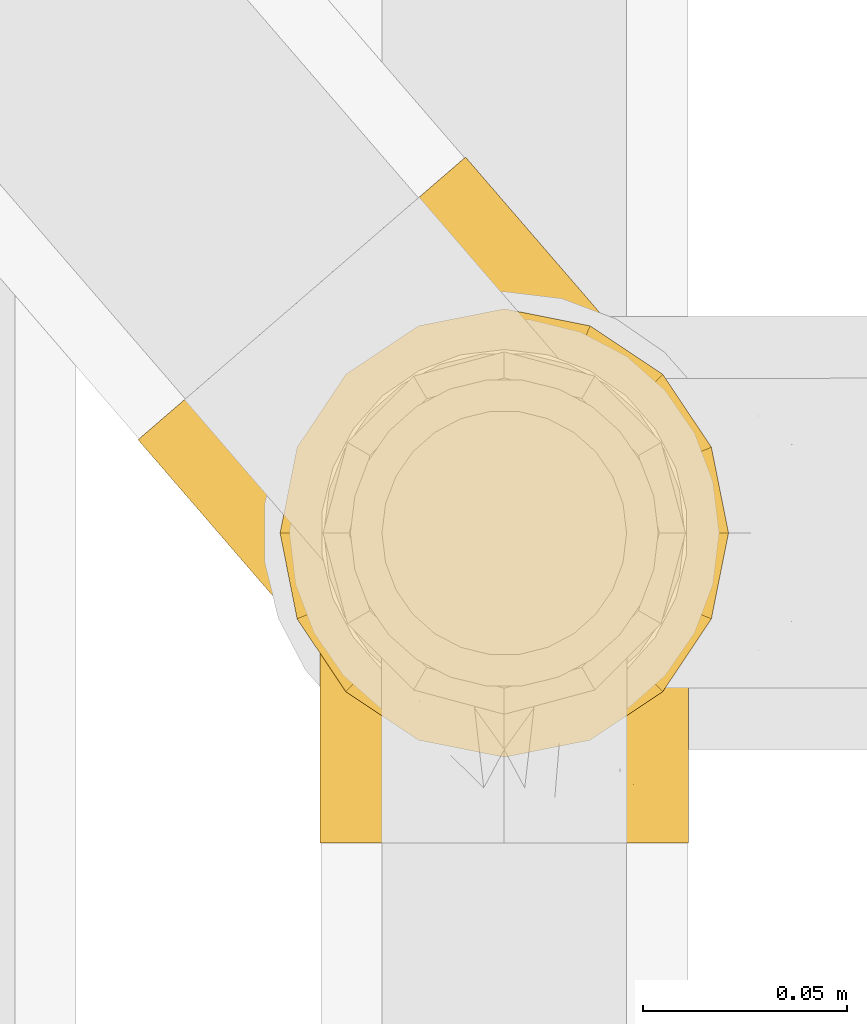
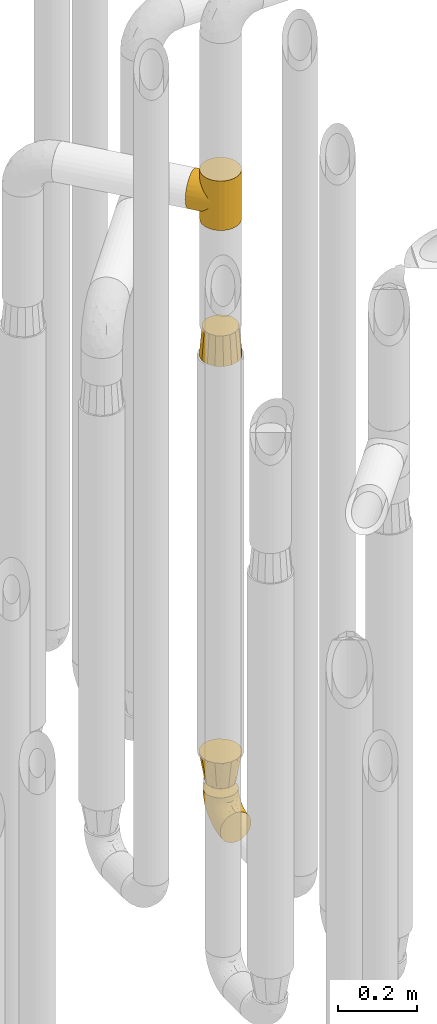
# One storey, part 217 of 827: 4 coverings.
"""IFC2X3 building model written with IfcOpenShell, lengths in millimetres."""

from ifc_helpers import new_model, entity, si_unit, converted_unit, derived_unit, direction, frame, origin, place, context, subcontext, project, spatial, faceted_brep, element, save


model = new_model("IFC2X3")

# Units and contexts
model_context = context("Model", 3, precision=0.01, world=origin(), true_north=direction((6.12303176911189e-17, 1.0)))
body_context = subcontext(model_context, "Body", "Model", "MODEL_VIEW")
ifc_project = project(units=[si_unit("LENGTHUNIT", "METRE", prefix="MILLI"), si_unit("AREAUNIT", "SQUARE_METRE"), si_unit("VOLUMEUNIT", "CUBIC_METRE"), converted_unit("PLANEANGLEUNIT", "DEGREE", entity("IfcRatioMeasure", 0.0174532925199433), si_unit("PLANEANGLEUNIT", "RADIAN"), dimensions=[0, 0, 0, 0, 0, 0, 0]), si_unit("MASSUNIT", "GRAM", prefix="KILO"), derived_unit("MASSDENSITYUNIT", [(si_unit("MASSUNIT", "GRAM", prefix="KILO"), 1), (si_unit("LENGTHUNIT", "METRE"), -3)]), derived_unit("MOMENTOFINERTIAUNIT", [(si_unit("LENGTHUNIT", "METRE"), 4)]), si_unit("TIMEUNIT", "SECOND"), si_unit("FREQUENCYUNIT", "HERTZ"), si_unit("THERMODYNAMICTEMPERATUREUNIT", "DEGREE_CELSIUS"), derived_unit("THERMALTRANSMITTANCEUNIT", [(si_unit("MASSUNIT", "GRAM", prefix="KILO"), 1), (si_unit("THERMODYNAMICTEMPERATUREUNIT", "KELVIN"), -1), (si_unit("TIMEUNIT", "SECOND"), -3)]), derived_unit("VOLUMETRICFLOWRATEUNIT", [(si_unit("LENGTHUNIT", "METRE"), 3), (si_unit("TIMEUNIT", "SECOND"), -1)]), derived_unit("MASSFLOWRATEUNIT", [(si_unit("MASSUNIT", "GRAM", prefix="KILO"), 1), (si_unit("TIMEUNIT", "SECOND"), -1)]), derived_unit("ROTATIONALFREQUENCYUNIT", [(si_unit("TIMEUNIT", "SECOND"), -1)]), si_unit("ELECTRICCURRENTUNIT", "AMPERE"), si_unit("ELECTRICVOLTAGEUNIT", "VOLT"), si_unit("POWERUNIT", "WATT"), si_unit("FORCEUNIT", "NEWTON", prefix="KILO"), si_unit("ILLUMINANCEUNIT", "LUX"), si_unit("LUMINOUSFLUXUNIT", "LUMEN"), si_unit("LUMINOUSINTENSITYUNIT", "CANDELA"), derived_unit("USERDEFINED", [(si_unit("MASSUNIT", "GRAM", prefix="KILO"), -1), (si_unit("LENGTHUNIT", "METRE"), -2), (si_unit("TIMEUNIT", "SECOND"), 3), (si_unit("LUMINOUSFLUXUNIT", "LUMEN"), 1)]), derived_unit("LINEARVELOCITYUNIT", [(si_unit("LENGTHUNIT", "METRE"), 1), (si_unit("TIMEUNIT", "SECOND"), -1)]), si_unit("PRESSUREUNIT", "PASCAL"), derived_unit("USERDEFINED", [(si_unit("LENGTHUNIT", "METRE"), -2), (si_unit("MASSUNIT", "GRAM", prefix="KILO"), 1), (si_unit("TIMEUNIT", "SECOND"), -2)]), derived_unit("LINEARFORCEUNIT", [(si_unit("MASSUNIT", "GRAM", prefix="KILO"), 1), (si_unit("LENGTHUNIT", "METRE"), 1), (si_unit("TIMEUNIT", "SECOND"), -2), (si_unit("LENGTHUNIT", "METRE"), -1)]), derived_unit("PLANARFORCEUNIT", [(si_unit("MASSUNIT", "GRAM", prefix="KILO"), 1), (si_unit("LENGTHUNIT", "METRE"), 1), (si_unit("TIMEUNIT", "SECOND"), -2), (si_unit("LENGTHUNIT", "METRE"), -2)])], contexts=[model_context])

# Site, building, storey
site_placement = place(None, origin())
site = spatial("IfcSite", under=ifc_project, at=site_placement, CompositionType="ELEMENT")
building_placement = place(site_placement, origin())
building = spatial("IfcBuilding", under=site, at=building_placement, CompositionType="ELEMENT")
storey_placement = place(building_placement, frame((0.0, 0.0, 28200.0)))
storey = spatial("IfcBuildingStorey", under=building, at=storey_placement, Name="08", CompositionType="ELEMENT", Elevation=28200.0)

# Coverings
covering_1_placement = place(storey_placement, frame((36928.29, 11252.61, 353.25)))
element("IfcCovering", 1, at=covering_1_placement, inside=storey, Name=":ADSK_", ObjectType=":ADSK_", PredefinedType="INSULATION", context=body_context, shape_type="Brep", body=[
    faceted_brep([(90.76, 87.65, 122.75), (87.42, 97.19, 122.75), (82.04, 105.75, 122.75), (74.89, 112.9, 122.75), (66.33, 118.28, 122.75), (56.79, 121.61, 122.75), (46.75, 122.75, 122.75), (36.69, 121.61, 122.75), (27.15, 118.27, 122.75), (18.59, 112.89, 122.75), (11.44, 105.74, 122.75), (6.06, 97.18, 122.75), (2.73, 87.64, 122.75), (1.6, 77.6, 122.75), (2.73, 67.54, 122.75), (6.07, 58.0, 122.75), (11.45, 49.44, 122.75), (18.6, 42.29, 122.75), (27.16, 36.91, 122.75), (36.7, 33.58, 122.75), (46.75, 32.45, 122.75), (56.8, 33.58, 122.75), (66.34, 36.92, 122.75), (74.9, 42.3, 122.75), (82.05, 49.45, 122.75), (87.43, 58.01, 122.75), (90.76, 67.55, 122.75), (91.9, 77.6, 122.75), (35.06, 1.6, 90.36), (24.17, 1.6, 85.85), (14.82, 1.6, 78.67), (7.64, 1.6, 69.32), (3.13, 1.6, 58.43), (1.6, 1.6, 46.75), (3.13, 1.6, 35.06), (7.64, 1.6, 24.17), (14.82, 1.6, 14.82), (24.17, 1.6, 7.64), (35.06, 1.6, 3.13), (46.75, 1.6, 1.6), (58.43, 1.6, 3.13), (69.32, 1.6, 7.64), (78.67, 1.6, 14.82), (85.85, 1.6, 24.17), (90.36, 1.6, 35.06), (91.9, 1.6, 46.75), (90.36, 1.6, 58.43), (85.85, 1.6, 69.32), (78.67, 1.6, 78.67), (69.32, 1.6, 85.85), (58.43, 1.6, 90.36), (46.75, 1.6, 91.9), (46.75, 99.61, 51.54), (55.2, 95.26, 47.17), (46.75, 86.21, 38.13), (46.75, 39.03, 7.52), (54.53, 30.75, 5.85), (46.75, 23.8, 5.11), (59.63, 60.8, 19.2), (62.07, 85.37, 38.98), (71.86, 73.64, 35.02), (62.65, 31.01, 8.21), (71.33, 49.14, 19.28), (72.93, 23.88, 12.19), (91.2, 82.74, 101.39), (86.31, 43.48, 34.43), (80.89, 29.47, 20.95), (79.49, 56.38, 30.74), (90.68, 72.18, 72.93), (86.84, 72.24, 56.64), (87.38, 87.6, 80.81), (76.87, 107.24, 93.43), (83.73, 101.1, 100.76), (81.03, 95.16, 74.27), (91.9, 71.81, 93.66), (91.9, 63.57, 81.33), (91.9, 55.34, 69.01), (91.03, 23.66, 40.87), (87.58, 20.55, 29.38), (56.52, 107.97, 67.05), (46.75, 116.82, 85.31), (60.4, 117.03, 93.68), (91.9, 30.68, 52.53), (91.9, 21.51, 50.71), (91.9, 12.33, 48.88), (67.87, 106.17, 72.77), (90.35, 52.37, 51.21), (69.57, 114.51, 101.18), (46.75, 119.23, 100.54), (79.91, 78.37, 48.74), (91.9, 75.46, 112.01), (91.9, 73.63, 102.83), (74.99, 101.51, 73.88), (46.75, 72.81, 24.73), (91.9, 43.01, 60.77), (88.53, 92.6, 103.08), (72.65, 91.86, 54.8), (46.75, 55.92, 16.13), (62.97, 99.01, 55.92), (46.75, 108.21, 68.42), (66.2, 32.05, 104.98), (56.6, 30.22, 108.58), (59.89, 23.37, 98.21), (90.95, 28.43, 61.56), (90.22, 16.44, 60.69), (76.64, 37.1, 100.0), (71.58, 28.88, 95.88), (79.99, 33.93, 90.81), (89.54, 50.17, 84.88), (89.97, 40.57, 73.29), (81.32, 47.62, 113.4), (74.56, 39.9, 109.8), (84.15, 47.92, 102.13), (90.37, 34.27, 67.29), (87.82, 24.65, 70.34), (90.98, 62.6, 95.15), (90.96, 66.18, 105.49), (85.14, 11.74, 71.5), (58.11, 13.89, 92.87), (46.75, 17.02, 96.03), (78.39, 15.86, 81.34), (88.22, 57.71, 107.44), (66.06, 9.11, 88.36), (68.6, 18.55, 90.43), (63.78, 34.74, 114.37), (88.42, 54.95, 98.41), (90.61, 57.35, 88.73), (83.8, 22.03, 76.89), (77.98, 24.8, 86.08), (91.22, 69.07, 112.64), (83.46, 42.31, 94.21), (46.75, 29.63, 112.22), (46.75, 28.31, 107.32), (84.66, 30.23, 79.95), (86.33, 40.13, 84.51), (46.75, 22.67, 101.67), (46.75, 12.12, 94.71), (15.1, 15.86, 81.34), (9.69, 22.03, 76.89), (15.52, 24.8, 86.08), (8.83, 30.23, 79.96), (35.39, 13.88, 92.87), (12.18, 47.61, 113.41), (1.6, 73.63, 102.83), (2.53, 66.17, 105.5), (2.27, 69.07, 112.64), (36.9, 30.22, 108.58), (27.31, 32.04, 104.98), (33.62, 23.36, 98.2), (5.07, 54.93, 98.4), (9.36, 47.91, 102.13), (5.27, 57.69, 107.44), (27.43, 9.1, 88.36), (1.6, 21.51, 50.71), (1.6, 12.33, 48.88), (10.05, 42.29, 94.22), (16.87, 37.09, 100.01), (8.35, 11.74, 71.5), (3.27, 16.44, 60.69), (1.6, 30.68, 52.53), (21.94, 28.86, 95.89), (29.72, 34.74, 114.37), (1.6, 63.57, 81.33), (1.6, 55.34, 69.01), (3.96, 50.17, 84.88), (1.6, 75.46, 112.01), (18.95, 39.89, 109.8), (2.54, 28.43, 61.56), (3.12, 34.27, 67.29), (1.6, 43.01, 60.77), (2.51, 62.59, 95.14), (3.52, 40.57, 73.29), (7.17, 40.13, 84.53), (1.6, 71.81, 93.66), (13.52, 33.92, 90.82), (2.88, 57.34, 88.73), (5.67, 24.65, 70.34), (24.89, 18.54, 90.43), (12.6, 29.47, 20.95), (7.18, 43.48, 34.43), (14.0, 56.4, 30.74), (22.16, 49.17, 19.29), (21.61, 73.69, 35.07), (3.14, 52.37, 51.21), (6.65, 72.26, 56.67), (20.82, 91.88, 54.85), (31.41, 85.36, 38.98), (5.91, 20.55, 29.38), (2.46, 23.66, 40.87), (33.87, 60.8, 19.2), (30.84, 31.02, 8.21), (38.96, 30.75, 5.85), (20.56, 23.9, 12.19), (2.81, 72.17, 72.93), (6.1, 87.59, 80.83), (2.29, 82.74, 101.39), (33.08, 117.03, 93.69), (16.61, 107.23, 93.43), (36.96, 107.97, 67.04), (9.75, 101.08, 100.76), (25.61, 106.17, 72.78), (30.5, 99.01, 55.93), (23.91, 114.5, 101.18), (12.45, 95.15, 74.27), (18.49, 101.5, 73.89), (4.96, 92.59, 103.09), (13.56, 78.38, 48.78), (38.28, 95.27, 47.19)], [[[0, 1, 2, 3, 4, 5, 6, 7, 8, 9, 10, 11, 12, 13, 14, 15, 16, 17, 18, 19, 20, 21, 22, 23, 24, 25, 26, 27]], [[28, 29, 30, 31, 32, 33, 34, 35, 36, 37, 38, 39, 40, 41, 42, 43, 44, 45, 46, 47, 48, 49, 50, 51]], [[52, 53, 54]], [[55, 56, 57]], [[58, 59, 60]], [[61, 62, 63]], [[27, 64, 0]], [[65, 66, 67]], [[41, 40, 61]], [[68, 69, 70]], [[66, 43, 42]], [[63, 42, 41]], [[71, 72, 73]], [[72, 2, 1]], [[68, 74, 75, 76]], [[45, 44, 77]], [[43, 78, 44]], [[79, 80, 81]], [[77, 82, 83, 84, 45]], [[79, 81, 85]], [[71, 2, 72]], [[65, 86, 77]], [[4, 81, 5]], [[66, 65, 78]], [[4, 3, 87]], [[81, 88, 5]], [[63, 66, 42]], [[68, 70, 64]], [[67, 60, 89]], [[71, 3, 2]], [[64, 27, 90, 91, 74]], [[92, 71, 73]], [[40, 57, 56]], [[59, 93, 54]], [[86, 76, 94, 82]], [[1, 0, 95]], [[58, 62, 61]], [[60, 96, 89]], [[85, 81, 87]], [[56, 97, 58]], [[65, 67, 69]], [[87, 81, 4]], [[67, 89, 69]], [[61, 63, 41]], [[95, 72, 1]], [[73, 72, 70]], [[69, 73, 70]], [[73, 89, 96]], [[3, 71, 87]], [[85, 87, 71]], [[58, 61, 56]], [[59, 58, 93]], [[76, 86, 68]], [[69, 89, 73]], [[68, 86, 69]], [[65, 69, 86]], [[68, 64, 74]], [[95, 64, 70]], [[98, 79, 85]], [[79, 52, 99, 80]], [[66, 62, 67]], [[62, 58, 60]], [[62, 60, 67]], [[59, 98, 96]], [[59, 96, 60]], [[96, 85, 92]], [[88, 81, 80]], [[88, 6, 5]], [[66, 63, 62]], [[64, 95, 0]], [[72, 95, 70]], [[77, 44, 78]], [[86, 82, 77]], [[40, 39, 57]], [[96, 98, 85]], [[40, 56, 61]], [[66, 78, 43]], [[77, 78, 65]], [[79, 98, 53]], [[96, 92, 73]], [[85, 71, 92]], [[97, 56, 55]], [[97, 93, 58]], [[53, 98, 59]], [[54, 53, 59]], [[79, 53, 52]], [[100, 101, 102]], [[46, 45, 84, 83]], [[103, 104, 82]], [[82, 104, 83]], [[105, 106, 107]], [[108, 109, 76]], [[110, 111, 112]], [[103, 113, 114]], [[115, 74, 116]], [[48, 47, 117]], [[118, 102, 119]], [[49, 48, 120]], [[74, 91, 116]], [[116, 121, 115]], [[49, 122, 50]], [[123, 106, 102]], [[124, 111, 22]], [[125, 126, 115]], [[23, 22, 111]], [[24, 110, 121]], [[120, 127, 128]], [[90, 26, 129]], [[27, 26, 90]], [[121, 125, 115]], [[24, 121, 25]], [[130, 105, 107]], [[129, 25, 116]], [[21, 20, 131]], [[120, 123, 122]], [[112, 105, 130]], [[50, 118, 51]], [[21, 124, 22]], [[101, 131, 132]], [[117, 120, 48]], [[24, 23, 110]], [[127, 114, 133]], [[75, 108, 76]], [[107, 134, 130]], [[133, 114, 113]], [[129, 116, 91]], [[25, 121, 116]], [[121, 112, 125]], [[75, 74, 115]], [[101, 135, 102]], [[131, 101, 21]], [[101, 100, 124]], [[128, 127, 133]], [[119, 136, 51, 118]], [[104, 47, 46]], [[83, 104, 46]], [[117, 104, 114]], [[101, 124, 21]], [[111, 124, 100]], [[102, 118, 123]], [[133, 134, 107]], [[111, 110, 23]], [[114, 104, 103]], [[94, 76, 109]], [[121, 110, 112]], [[122, 118, 50]], [[134, 109, 108]], [[133, 107, 128]], [[112, 108, 125]], [[126, 125, 108]], [[108, 75, 126]], [[75, 115, 126]], [[109, 134, 133]], [[130, 108, 112]], [[108, 130, 134]], [[105, 112, 111]], [[111, 100, 105]], [[106, 105, 100]], [[102, 106, 100]], [[128, 106, 123]], [[90, 129, 91]], [[25, 129, 26]], [[104, 117, 47]], [[117, 114, 127]], [[82, 94, 103]], [[113, 94, 109]], [[94, 113, 103]], [[133, 113, 109]], [[106, 128, 107]], [[123, 120, 128]], [[120, 122, 49]], [[118, 122, 123]], [[135, 101, 132]], [[135, 119, 102]], [[117, 127, 120]], [[30, 29, 137]], [[138, 139, 140]], [[51, 136, 119, 141]], [[142, 17, 16]], [[143, 144, 145]], [[146, 147, 148]], [[149, 150, 151]], [[152, 29, 28]], [[33, 32, 153, 154]], [[150, 155, 156]], [[157, 31, 30]], [[153, 158, 159]], [[29, 152, 137]], [[148, 141, 119]], [[156, 160, 147]], [[148, 135, 146]], [[137, 138, 157]], [[19, 161, 146]], [[162, 163, 164]], [[14, 13, 165]], [[153, 32, 158]], [[147, 161, 166]], [[18, 17, 166]], [[167, 168, 169]], [[166, 150, 156]], [[151, 150, 142]], [[151, 170, 149]], [[151, 16, 15]], [[171, 140, 172]], [[165, 143, 145]], [[173, 170, 144]], [[142, 166, 17]], [[19, 131, 20]], [[144, 170, 151]], [[18, 161, 19]], [[173, 144, 143]], [[140, 139, 174]], [[171, 164, 163]], [[164, 172, 155]], [[151, 15, 144]], [[145, 15, 14]], [[173, 162, 170]], [[149, 175, 164]], [[19, 146, 131]], [[132, 131, 146]], [[160, 148, 147]], [[159, 158, 167]], [[135, 132, 146]], [[158, 32, 31]], [[157, 158, 31]], [[167, 158, 176]], [[166, 161, 18]], [[146, 161, 147]], [[148, 177, 141]], [[171, 168, 140]], [[171, 163, 169]], [[151, 142, 16]], [[166, 142, 150]], [[152, 141, 177]], [[51, 141, 28]], [[138, 140, 176]], [[172, 140, 174]], [[175, 149, 170]], [[164, 150, 149]], [[170, 162, 175]], [[162, 164, 175]], [[155, 172, 174]], [[171, 172, 164]], [[155, 174, 156]], [[164, 155, 150]], [[160, 156, 174]], [[147, 166, 156]], [[139, 160, 174]], [[148, 160, 177]], [[15, 145, 144]], [[165, 145, 14]], [[137, 157, 30]], [[158, 157, 176]], [[168, 167, 176]], [[169, 159, 167]], [[140, 168, 176]], [[169, 168, 171]], [[137, 177, 139]], [[160, 139, 177]], [[141, 152, 28]], [[137, 152, 177]], [[148, 119, 135]], [[157, 138, 176]], [[139, 138, 137]], [[178, 179, 180]], [[181, 180, 182]], [[179, 183, 184]], [[185, 186, 182]], [[187, 188, 179]], [[188, 33, 154, 153, 159]], [[181, 189, 190]], [[35, 34, 187]], [[191, 38, 190]], [[192, 178, 181]], [[179, 184, 180]], [[192, 190, 37]], [[37, 190, 38]], [[36, 35, 178]], [[54, 93, 186]], [[35, 187, 178]], [[193, 194, 184]], [[195, 173, 143, 165, 13]], [[195, 193, 173]], [[193, 163, 162, 173]], [[13, 12, 195]], [[8, 7, 196]], [[9, 197, 10]], [[198, 80, 99, 52]], [[196, 7, 88]], [[197, 199, 10]], [[182, 189, 181]], [[200, 198, 201]], [[200, 196, 198]], [[9, 8, 202]], [[194, 199, 203]], [[192, 37, 36]], [[80, 196, 88]], [[183, 159, 169, 163]], [[188, 34, 33]], [[202, 200, 197]], [[185, 203, 204]], [[202, 8, 196]], [[10, 199, 11]], [[12, 11, 205]], [[38, 191, 57]], [[189, 97, 191]], [[203, 199, 197]], [[205, 199, 194]], [[204, 203, 197]], [[184, 203, 206]], [[200, 202, 196]], [[197, 9, 202]], [[207, 54, 186]], [[97, 55, 191]], [[194, 203, 184]], [[183, 163, 193]], [[184, 206, 180]], [[183, 193, 184]], [[205, 195, 12]], [[193, 195, 194]], [[80, 198, 196]], [[207, 186, 201]], [[182, 180, 206]], [[181, 178, 180]], [[185, 182, 206]], [[182, 186, 189]], [[203, 185, 206]], [[185, 200, 201]], [[7, 6, 88]], [[178, 192, 36]], [[190, 192, 181]], [[199, 205, 11]], [[195, 205, 194]], [[159, 183, 188]], [[179, 188, 183]], [[57, 191, 55]], [[57, 39, 38]], [[189, 191, 190]], [[188, 187, 34]], [[178, 187, 179]], [[186, 93, 189]], [[197, 200, 204]], [[185, 204, 200]], [[189, 93, 97]], [[207, 198, 52]], [[185, 201, 186]], [[198, 207, 201]], [[54, 207, 52]]]),
])
covering_2_placement = place(storey_placement, frame((36883.62, 11275.7, 2229.0)))
element("IfcCovering", 2, at=covering_2_placement, inside=storey, Name=":ADSK_", ObjectType=":ADSK_", PredefinedType="INSULATION", context=body_context, shape_type="Brep", body=[
    faceted_brep([(49.11, 86.52, 24.13), (56.75, 94.67, 22.95), (56.75, 94.67, 0.0), (56.75, 94.67, 129.05), (49.11, 86.52, 127.87), (56.75, 94.67, 152.0), (47.54, 84.33, 0.0), (43.53, 77.34, 27.43), (44.43, 78.14, 0.0), (41.31, 71.96, 0.0), (38.5, 58.4, 0.0), (38.51, 58.49, 38.42), (40.06, 67.84, 32.36), (38.59, 49.55, 45.24), (39.3, 44.57, 0.0), (40.07, 41.15, 52.57), (43.64, 31.42, 0.0), (46.51, 26.24, 68.06), (51.25, 19.84, 0.0), (42.75, 33.36, 60.22), (51.25, 19.84, 76.0), (46.51, 26.24, 83.94), (51.25, 19.84, 152.0), (126.54, 94.25, 68.86), (131.57, 89.16, 0.0), (121.24, 98.37, 0.0), (108.86, 104.6, 0.0), (114.42, 102.3, 54.84), (99.72, 106.9, 41.76), (95.3, 107.41, 0.0), (107.37, 105.09, 48.13), (131.57, 89.16, 76.0), (126.54, 94.25, 83.14), (131.57, 89.16, 152.0), (120.81, 98.66, 61.78), (91.49, 107.55, 35.89), (81.48, 106.61, 0.0), (73.82, 104.55, 26.62), (74.9, 104.44, 0.0), (68.33, 102.27, 0.0), (62.54, 98.47, 0.0), (62.54, 98.47, 152.0), (82.79, 106.85, 30.74), (64.96, 100.49, 23.9), (114.49, 6.74, 152.0), (126.07, 14.34, 152.0), (135.28, 24.68, 152.0), (141.51, 37.05, 152.0), (144.32, 50.61, 152.0), (143.52, 64.43, 152.0), (139.18, 77.58, 152.0), (121.24, 98.37, 152.0), (108.86, 104.6, 152.0), (95.3, 107.41, 152.0), (81.48, 106.61, 152.0), (74.9, 104.44, 152.0), (68.33, 102.27, 152.0), (47.54, 84.33, 152.0), (44.43, 78.14, 152.0), (41.31, 71.96, 152.0), (38.5, 58.4, 152.0), (39.3, 44.57, 152.0), (43.64, 31.42, 152.0), (61.58, 10.63, 152.0), (73.96, 4.41, 152.0), (87.52, 1.6, 152.0), (101.34, 2.39, 152.0), (139.18, 77.58, 0.0), (143.52, 64.43, 0.0), (144.32, 50.61, 0.0), (141.51, 37.05, 0.0), (135.28, 24.68, 0.0), (126.07, 14.34, 0.0), (114.49, 6.74, 0.0), (101.34, 2.39, 0.0), (87.52, 1.6, 0.0), (73.96, 4.41, 0.0), (61.58, 10.63, 0.0), (120.81, 98.66, 90.22), (114.42, 102.3, 97.16), (107.37, 105.09, 103.87), (99.72, 106.9, 110.24), (91.49, 107.55, 116.11), (82.79, 106.85, 121.26), (73.82, 104.55, 125.38), (64.96, 100.49, 128.1), (43.53, 77.34, 124.57), (40.06, 67.84, 119.64), (38.51, 58.49, 113.58), (40.07, 41.15, 99.43), (42.75, 33.36, 91.78), (38.59, 49.55, 106.76), (81.92, 146.7, 76.0), (80.55, 145.52, 62.27), (76.54, 142.06, 49.47), (70.16, 136.55, 38.49), (61.84, 129.37, 30.06), (57.0, 125.19, 27.41), (52.15, 121.01, 24.76), (46.96, 116.53, 23.85), (41.76, 112.04, 22.95), (31.36, 103.07, 24.76), (26.52, 98.89, 27.41), (21.68, 94.71, 30.06), (13.36, 87.54, 38.49), (6.98, 82.03, 49.47), (2.96, 78.56, 62.27), (1.6, 77.38, 76.0), (2.96, 78.56, 89.73), (6.98, 82.03, 102.53), (13.36, 87.54, 113.51), (21.68, 94.71, 121.94), (26.52, 98.89, 124.59), (31.36, 103.07, 127.24), (41.76, 112.04, 129.05), (46.96, 116.53, 128.15), (52.15, 121.01, 127.24), (57.0, 125.19, 124.59), (61.84, 129.37, 121.94), (70.16, 136.55, 113.51), (76.54, 142.06, 102.53), (80.55, 145.52, 89.73)], [[[0, 1, 2]], [[3, 4, 5]], [[0, 2, 6]], [[7, 6, 8, 9]], [[7, 0, 6]], [[10, 11, 12]], [[7, 9, 12]], [[12, 9, 10]], [[13, 10, 14]], [[15, 14, 16]], [[17, 16, 18]], [[15, 13, 14]], [[17, 19, 16]], [[20, 17, 18]], [[21, 20, 22]], [[15, 16, 19]], [[10, 13, 11]], [[23, 24, 25]], [[25, 26, 27]], [[28, 26, 29]], [[28, 30, 26]], [[23, 31, 24]], [[31, 32, 33]], [[27, 34, 25]], [[30, 27, 26]], [[23, 25, 34]], [[35, 29, 36]], [[37, 36, 38, 39]], [[40, 2, 1]], [[41, 3, 5]], [[42, 35, 36]], [[43, 37, 39]], [[43, 40, 1]], [[43, 39, 40]], [[42, 36, 37]], [[29, 35, 28]], [[44, 45, 46, 47, 48, 49, 50, 33, 51, 52, 53, 54, 55, 56, 41, 5, 57, 58, 59, 60, 61, 62, 22, 63, 64, 65, 66]], [[24, 67, 68, 69, 70, 71, 72, 73, 74, 75, 76, 77, 18, 16, 14, 10, 9, 8, 6, 2, 40, 39, 38, 36, 29, 26, 25]], [[70, 69, 48, 47]], [[45, 72, 71, 46]], [[46, 71, 70, 47]], [[49, 68, 67, 50]], [[24, 31, 33, 50, 67]], [[48, 69, 68, 49]], [[78, 79, 51]], [[32, 78, 51]], [[33, 32, 51]], [[52, 80, 81]], [[52, 51, 79]], [[52, 81, 53]], [[80, 52, 79]], [[82, 83, 54]], [[84, 56, 55, 54]], [[84, 85, 56]], [[3, 41, 85]], [[83, 84, 54]], [[53, 82, 54]], [[85, 41, 56]], [[82, 53, 81]], [[4, 86, 57]], [[59, 87, 60]], [[86, 59, 58, 57]], [[86, 87, 59]], [[5, 4, 57]], [[87, 88, 60]], [[89, 90, 62]], [[90, 21, 62]], [[60, 91, 61]], [[91, 60, 88]], [[89, 61, 91]], [[89, 62, 61]], [[21, 22, 62]], [[20, 18, 77, 63, 22]], [[63, 77, 76, 64]], [[76, 75, 65, 64]], [[65, 75, 74, 66]], [[66, 74, 73, 44]], [[44, 73, 72, 45]], [[92, 93, 94, 95, 96, 97, 98, 99, 100, 101, 102, 103, 104, 105, 106, 107, 108, 109, 110, 111, 112, 113, 114, 115, 116, 117, 118, 119, 120, 121]], [[43, 99, 98]], [[96, 95, 35]], [[37, 98, 97, 96]], [[1, 99, 43]], [[1, 100, 99]], [[42, 37, 96]], [[35, 42, 96]], [[43, 98, 37]], [[95, 28, 35]], [[30, 28, 94]], [[94, 28, 95]], [[27, 94, 93]], [[23, 93, 92]], [[27, 30, 94]], [[23, 34, 93]], [[31, 23, 92]], [[27, 93, 34]], [[32, 92, 121]], [[121, 120, 79]], [[81, 120, 119]], [[81, 80, 120]], [[32, 31, 92]], [[79, 78, 121]], [[80, 79, 120]], [[32, 121, 78]], [[82, 119, 118]], [[84, 118, 117, 116]], [[115, 114, 3]], [[83, 82, 118]], [[85, 84, 116]], [[85, 115, 3]], [[85, 116, 115]], [[83, 118, 84]], [[119, 82, 81]], [[4, 3, 114]], [[4, 114, 113]], [[86, 113, 112, 111]], [[86, 4, 113]], [[110, 88, 87]], [[86, 111, 87]], [[87, 111, 110]], [[91, 110, 109]], [[89, 109, 108]], [[21, 108, 107]], [[89, 91, 109]], [[21, 90, 108]], [[20, 21, 107]], [[89, 108, 90]], [[110, 91, 88]], [[17, 107, 106]], [[106, 105, 15]], [[13, 105, 104]], [[13, 15, 105]], [[17, 20, 107]], [[15, 19, 106]], [[17, 106, 19]], [[12, 104, 103]], [[7, 103, 102, 101]], [[0, 101, 100]], [[12, 11, 104]], [[0, 7, 101]], [[1, 0, 100]], [[12, 103, 7]], [[104, 11, 13]]]),
])
covering_3_placement = place(storey_placement, frame((36918.44, 11273.61, 500.0)))
element("IfcCovering", 3, at=covering_3_placement, inside=storey, Name=":ADSK_", ObjectType=":ADSK_", PredefinedType="INSULATION", context=body_context, shape_type="Brep", body=[
    faceted_brep([(5.78, 77.64, 89.0), (3.69, 67.12, 89.0), (1.6, 56.6, 89.0), (3.69, 46.07, 89.0), (5.78, 35.55, 89.0), (11.74, 26.63, 89.0), (17.7, 17.7, 89.0), (26.63, 11.74, 89.0), (35.55, 5.78, 89.0), (46.07, 3.69, 89.0), (56.6, 1.6, 89.0), (67.12, 3.69, 89.0), (77.64, 5.78, 89.0), (86.56, 11.74, 89.0), (95.49, 17.7, 89.0), (101.45, 26.63, 89.0), (107.41, 35.55, 89.0), (109.5, 46.07, 89.0), (111.6, 56.6, 89.0), (109.5, 67.12, 89.0), (107.41, 77.64, 89.0), (101.45, 86.56, 89.0), (95.49, 95.49, 89.0), (86.56, 101.45, 89.0), (77.64, 107.41, 89.0), (67.12, 109.5, 89.0), (56.6, 111.6, 89.0), (46.07, 109.5, 89.0), (35.55, 107.41, 89.0), (26.63, 101.45, 89.0), (17.7, 95.49, 89.0), (11.74, 86.56, 89.0), (91.24, 36.6, 0.0), (83.92, 29.27, 0.0), (76.6, 21.95, 0.0), (66.6, 19.27, 0.0), (56.6, 16.6, 0.0), (46.6, 19.27, 0.0), (36.6, 21.95, 0.0), (29.27, 29.27, 0.0), (21.95, 36.6, 0.0), (19.27, 46.6, 0.0), (16.6, 56.6, 0.0), (19.27, 66.6, 0.0), (21.95, 76.6, 0.0), (29.27, 83.92, 0.0), (36.6, 91.24, 0.0), (46.6, 93.92, 0.0), (56.6, 96.6, 0.0), (66.6, 93.92, 0.0), (76.6, 91.24, 0.0), (83.92, 83.92, 0.0), (91.24, 76.6, 0.0), (93.92, 66.6, 0.0), (96.6, 56.6, 0.0), (93.92, 46.6, 0.0)], [[[0, 1, 2, 3, 4, 5, 6, 7, 8, 9, 10, 11, 12, 13, 14, 15, 16, 17, 18, 19, 20, 21, 22, 23, 24, 25, 26, 27, 28, 29, 30, 31]], [[32, 33, 34, 35, 36, 37, 38, 39, 40, 41, 42, 43, 44, 45, 46, 47, 48, 49, 50, 51, 52, 53, 54, 55]], [[27, 26, 48]], [[44, 31, 45]], [[45, 29, 46]], [[48, 47, 27]], [[30, 45, 31]], [[44, 0, 31]], [[29, 45, 30]], [[42, 1, 43]], [[29, 28, 46]], [[47, 46, 28]], [[1, 42, 2]], [[0, 44, 43]], [[1, 0, 43]], [[47, 28, 27]], [[3, 2, 42]], [[38, 7, 39]], [[39, 5, 40]], [[42, 41, 3]], [[6, 39, 7]], [[38, 8, 7]], [[5, 39, 6]], [[36, 9, 37]], [[5, 4, 40]], [[41, 40, 4]], [[9, 36, 10]], [[8, 38, 37]], [[9, 8, 37]], [[41, 4, 3]], [[11, 10, 36]], [[32, 15, 33]], [[33, 13, 34]], [[36, 35, 11]], [[14, 33, 15]], [[32, 16, 15]], [[13, 33, 14]], [[54, 17, 55]], [[13, 12, 34]], [[35, 34, 12]], [[17, 54, 18]], [[16, 32, 55]], [[17, 16, 55]], [[35, 12, 11]], [[19, 18, 54]], [[50, 23, 51]], [[51, 21, 52]], [[54, 53, 19]], [[22, 51, 23]], [[50, 24, 23]], [[21, 51, 22]], [[48, 25, 49]], [[21, 20, 52]], [[53, 52, 20]], [[25, 48, 26]], [[24, 50, 49]], [[25, 24, 49]], [[53, 20, 19]]]),
])
covering_4_placement = place(storey_placement, frame((36918.44, 11273.61, 1811.0)))
element("IfcCovering", 4, at=covering_4_placement, inside=storey, Name=":ADSK_", ObjectType=":ADSK_", PredefinedType="INSULATION", context=body_context, shape_type="Brep", body=[
    faceted_brep([(56.6, 104.1, 89.0), (47.51, 102.29, 89.0), (38.42, 100.48, 89.0), (30.71, 95.33, 89.0), (23.01, 90.18, 89.0), (17.86, 82.48, 89.0), (12.71, 74.77, 89.0), (10.9, 65.68, 89.0), (9.1, 56.6, 89.0), (10.9, 47.51, 89.0), (12.71, 38.42, 89.0), (17.86, 30.71, 89.0), (23.01, 23.01, 89.0), (30.71, 17.86, 89.0), (38.42, 12.71, 89.0), (47.51, 10.9, 89.0), (56.6, 9.1, 89.0), (65.68, 10.9, 89.0), (74.77, 12.71, 89.0), (82.48, 17.86, 89.0), (90.18, 23.01, 89.0), (95.33, 30.71, 89.0), (100.48, 38.42, 89.0), (102.29, 47.51, 89.0), (104.1, 56.6, 89.0), (102.29, 65.68, 89.0), (100.48, 74.77, 89.0), (95.33, 82.48, 89.0), (90.18, 90.18, 89.0), (82.48, 95.33, 89.0), (74.77, 100.48, 89.0), (65.68, 102.29, 89.0), (77.64, 5.78, 0.0), (69.69, 4.2, 0.0), (56.6, 1.6, 0.0), (43.51, 4.2, 0.0), (35.55, 5.78, 0.0), (26.63, 11.74, 0.0), (17.7, 17.7, 0.0), (11.74, 26.63, 0.0), (5.78, 35.55, 0.0), (4.2, 43.51, 0.0), (1.6, 56.6, 0.0), (4.2, 69.69, 0.0), (5.78, 77.64, 0.0), (11.74, 86.56, 0.0), (17.7, 95.49, 0.0), (26.63, 101.45, 0.0), (35.55, 107.41, 0.0), (43.51, 108.99, 0.0), (56.6, 111.6, 0.0), (69.69, 108.99, 0.0), (77.64, 107.41, 0.0), (86.56, 101.45, 0.0), (95.49, 95.49, 0.0), (101.45, 86.56, 0.0), (107.41, 77.64, 0.0), (108.99, 69.69, 0.0), (111.6, 56.6, 0.0), (108.99, 43.51, 0.0), (107.41, 35.55, 0.0), (101.45, 26.63, 0.0), (95.49, 17.7, 0.0), (86.56, 11.74, 0.0)], [[[0, 1, 2, 3, 4, 5, 6, 7, 8, 9, 10, 11, 12, 13, 14, 15, 16, 17, 18, 19, 20, 21, 22, 23, 24, 25, 26, 27, 28, 29, 30, 31]], [[32, 33, 34, 35, 36, 37, 38, 39, 40, 41, 42, 43, 44, 45, 46, 47, 48, 49, 50, 51, 52, 53, 54, 55, 56, 57, 58, 59, 60, 61, 62, 63]], [[6, 44, 43, 42, 8, 7]], [[5, 4, 46, 45, 44, 6]], [[1, 0, 50, 49, 48, 2]], [[4, 3, 2, 48, 47, 46]], [[14, 36, 35, 34, 16, 15]], [[13, 12, 38, 37, 36, 14]], [[9, 8, 42, 41, 40, 10]], [[12, 11, 10, 40, 39, 38]], [[22, 60, 59, 58, 24, 23]], [[21, 20, 62, 61, 60, 22]], [[17, 16, 34, 33, 32, 18]], [[20, 19, 18, 32, 63, 62]], [[30, 52, 51, 50, 0, 31]], [[29, 28, 54, 53, 52, 30]], [[25, 24, 58, 57, 56, 26]], [[28, 27, 26, 56, 55, 54]]]),
])

save(model, "model.ifc")
